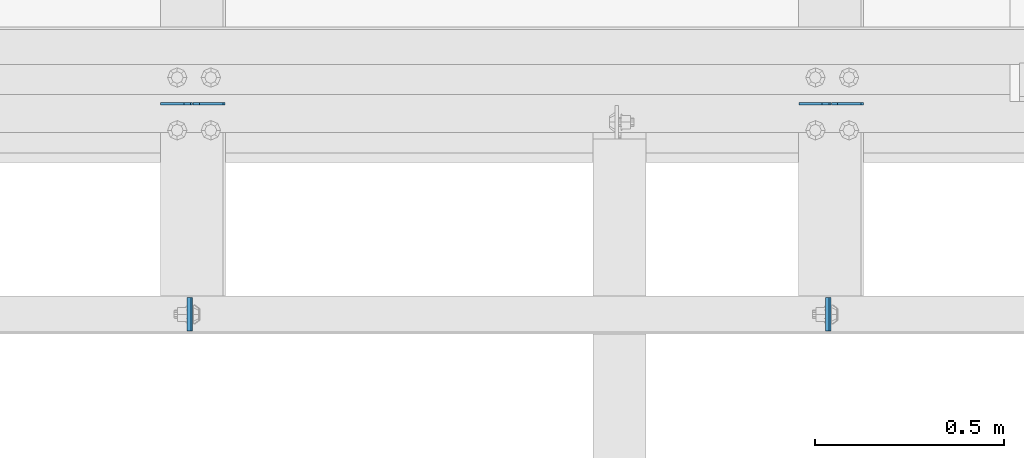
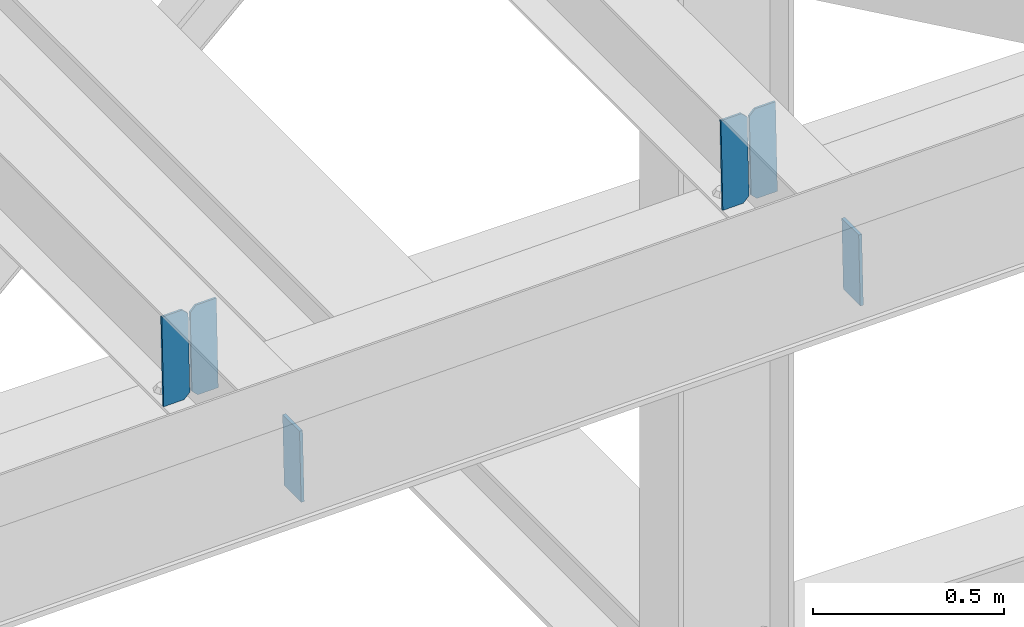
# One storey, part 3193 of 3843: 6 plates, 3 elements without a shape of their own.
"""IFC2X3 building model written with IfcOpenShell, lengths in millimetres."""

from ifc_helpers import new_model, si_unit, frame, origin_with_axes, place, context, subcontext, project, spatial, faceted_brep, material, type_object, element, aggregate, save


model = new_model("IFC2X3")

# Units and contexts
model_context = context("Model", 3, precision=1e-05, world=origin_with_axes())
body_context = subcontext(model_context, "Body", "Model", "MODEL_VIEW")
ifc_project = project(units=[si_unit("LENGTHUNIT", "METRE", prefix="MILLI"), si_unit("AREAUNIT", "SQUARE_METRE"), si_unit("VOLUMEUNIT", "CUBIC_METRE"), si_unit("MASSUNIT", "GRAM", prefix="KILO"), si_unit("TIMEUNIT", "SECOND"), si_unit("PLANEANGLEUNIT", "RADIAN"), si_unit("SOLIDANGLEUNIT", "STERADIAN"), si_unit("THERMODYNAMICTEMPERATUREUNIT", "DEGREE_CELSIUS"), si_unit("LUMINOUSINTENSITYUNIT", "LUMEN")], contexts=[model_context])

# Site, building, storey
site_placement = place(None, origin_with_axes())
site = spatial("IfcSite", under=ifc_project, at=site_placement, CompositionType="ELEMENT")
building_placement = place(site_placement, origin_with_axes())
building = spatial("IfcBuilding", under=site, at=building_placement, Name="Undefined", CompositionType="ELEMENT")
storey_placement = place(building_placement, origin_with_axes())
storey = spatial("IfcBuildingStorey", under=building, at=storey_placement, Name="Undefined", CompositionType="ELEMENT", Elevation=0.0)

# Assembly, plates
assembly_1_placement = place(storey_placement, origin_with_axes())
assembly_1 = element("IfcElementAssembly", 1, at=assembly_1_placement, inside=storey, Name="BEAM", AssemblyPlace="NOTDEFINED", PredefinedType="RIGID_FRAME")
ifc_material = material(Name="STEEL/A572-50")
plate_type_1 = type_object("IfcPlateType", PredefinedType="NOTDEFINED")
plate_1_placement = place(assembly_1_placement, frame((75309.9867956282, 25014.2377038333, 46511.0810232834), z_axis=(4.27769994857954e-05, 0.999999999084655, 9.05023924133274e-07), x_axis=(0.0211520550054438, 0.0, -0.999776270257025)))
plate_1 = element("IfcPlate", 2, at=plate_1_placement, type_object=plate_type_1, material=ifc_material, Name="PLATE", context=body_context, shape_type="Brep", body=[
    faceted_brep([(0.0, -4.76249999999709, 0.0), (0.0, -4.76249999999709, 88.9000015258789), (0.0, 4.76249999999709, 88.9000015258789), (0.0, 4.76249999999709, 0.0), (228.600006102781, -4.7625000004191, 88.9000015257589), (228.600006102781, 4.76249999954598, 88.9000015257443), (228.600006103079, -4.7625000004482, 7.27595761418343e-12), (228.600006103079, 4.76249999954598, -7.27595761418343e-12)], [[[0, 1, 2, 3]], [[1, 4, 5, 2]], [[4, 6, 7, 5]], [[6, 0, 3, 7]], [[5, 7, 3, 2]], [[6, 4, 1, 0]]]),
])
plate_2_placement = place(assembly_1_placement, frame((73620.886795624, 25014.2377038355, 46475.3449829727), z_axis=(4.27769994857954e-05, 0.999999999084655, 9.05023924133274e-07), x_axis=(0.0211520550054438, 0.0, -0.999776270257025)))
plate_2 = element("IfcPlate", 3, at=plate_2_placement, type_object=plate_type_1, material=ifc_material, Name="PLATE", context=body_context, shape_type="Brep", body=[
    faceted_brep([(0.0, -4.76249999999709, 0.0), (0.0, -4.76249999999709, 88.9000015258789), (0.0, 4.76249999999709, 88.9000015258789), (0.0, 4.76249999999709, 0.0), (228.600006102781, -4.7625000004191, 88.9000015257589), (228.600006102781, 4.76249999954598, 88.9000015257443), (228.600006103079, -4.7625000004482, 7.27595761418343e-12), (228.600006103079, 4.76249999954598, -7.27595761418343e-12)], [[[0, 1, 2, 3]], [[1, 4, 5, 2]], [[4, 6, 7, 5]], [[6, 0, 3, 7]], [[5, 7, 3, 2]], [[6, 4, 1, 0]]]),
])
aggregate(assembly_1, [plate_1, plate_2])

assembly_2_placement = place(storey_placement, origin_with_axes())
assembly_2 = element("IfcElementAssembly", 4, at=assembly_2_placement, inside=storey, Name="BEAM", AssemblyPlace="NOTDEFINED", PredefinedType="RIGID_FRAME")
plate_type_2 = type_object("IfcPlateType", PredefinedType="NOTDEFINED")
plate_3_placement = place(assembly_2_placement, frame((75405.9964782674, 25616.7954276443, 46252.244666368), z_axis=(-0.021152098282546, -0.00202236699979404, 0.999774223897558), x_axis=(-0.999776269341419, 4.27870000128944e-05, -0.0211520550071887)))
plate_3 = element("IfcPlate", 5, at=plate_3_placement, type_object=plate_type_2, material=ifc_material, Name="STIFFENER", context=body_context, shape_type="Brep", body=[
    faceted_brep([(0.0, -3.17499999999927, 0.0), (6.83940015733242e-10, -3.17499999996653, 288.924999998613), (6.54836185276508e-10, 3.17500000001746, 288.924999998591), (0.0, 3.17499999999927, 0.0), (61.9125003828667, -3.17499999997744, 288.924999998599), (61.9125003828522, 3.17500000002838, 288.924999998584), (79.3750000013097, -3.17499999997744, 271.462500380039), (79.375000001266, 3.17500000002838, 271.462500380017), (79.375000000713, -3.17499999999927, 17.4624996185448), (79.3750000006694, 3.17500000000291, 17.462499618523), (61.9125003821828, -3.17499999999563, -1.45519152283669e-11), (61.9125003821682, 3.17500000000655, -2.91038304567337e-11)], [[[0, 1, 2, 3]], [[1, 4, 5, 2]], [[4, 6, 7, 5]], [[6, 8, 9, 7]], [[8, 10, 11, 9]], [[10, 0, 3, 11]], [[5, 7, 9, 11, 3, 2]], [[10, 8, 6, 4, 1, 0]]]),
])
plate_4_placement = place(assembly_2_placement, frame((75320.2906575771, 25616.7990955481, 46250.431406477), z_axis=(-0.021152098282546, -0.00202236699979404, 0.999774223897558), x_axis=(-0.999776269341419, 4.27870000128944e-05, -0.0211520550071887)))
plate_4 = element("IfcPlate", 6, at=plate_4_placement, type_object=plate_type_2, material=ifc_material, Name="STIFFENER", context=body_context, shape_type="Brep", body=[
    faceted_brep([(5.82076609134674e-11, -3.17499999999927, 17.4624996185667), (6.25732354819775e-10, -3.17499999997744, 271.462500380054), (5.82076609134674e-10, 3.17500000002474, 271.462500380039), (0.0, 3.17500000000655, 17.4624996185521), (17.462499619156, -3.17499999997744, 288.924999998606), (17.4624996191269, 3.17500000002474, 288.924999998591), (79.3750000013242, -3.17500000025029, 288.924999998591), (79.3750000013097, 3.1749999997337, 288.92499999857), (79.3750000006548, -3.17500000026484, -2.18278728425503e-11), (79.3750000006403, 3.17499999969732, -2.91038304567337e-11), (17.4624996184866, -3.17500000000291, 7.27595761418343e-12), (17.462499618443, 3.17500000000291, -7.27595761418343e-12)], [[[0, 1, 2, 3]], [[1, 4, 5, 2]], [[4, 6, 7, 5]], [[6, 8, 9, 7]], [[8, 10, 11, 9]], [[10, 0, 3, 11]], [[5, 7, 9, 11, 3, 2]], [[10, 8, 6, 4, 1, 0]]]),
])
aggregate(assembly_2, [plate_3, plate_4])

assembly_3_placement = place(storey_placement, origin_with_axes())
assembly_3 = element("IfcElementAssembly", 7, at=assembly_3_placement, inside=storey, Name="BEAM", AssemblyPlace="NOTDEFINED", PredefinedType="RIGID_FRAME")
plate_5_placement = place(assembly_3_placement, frame((73716.8964782636, 25616.7954276443, 46216.5086260688), z_axis=(-0.021152098282546, -0.00202236699979404, 0.999774223897558), x_axis=(-0.999776269341419, 4.27870000128944e-05, -0.0211520550071887)))
plate_5 = element("IfcPlate", 8, at=plate_5_placement, type_object=plate_type_2, material=ifc_material, Name="STIFFENER", context=body_context, shape_type="Brep", body=[
    faceted_brep([(0.0, -3.17499999999927, 0.0), (6.83940015733242e-10, -3.17499999996653, 288.924999998613), (6.54836185276508e-10, 3.17500000001746, 288.924999998591), (0.0, 3.17499999999927, 0.0), (61.9125003828667, -3.17499999997744, 288.924999998599), (61.9125003828522, 3.17500000002838, 288.924999998584), (79.3750000013097, -3.17499999997744, 271.462500380039), (79.375000001266, 3.17500000002838, 271.462500380017), (79.375000000713, -3.17499999999927, 17.4624996185448), (79.3750000006694, 3.17500000000291, 17.462499618523), (61.9125003821828, -3.17499999999563, -1.45519152283669e-11), (61.9125003821682, 3.17500000000655, -2.91038304567337e-11)], [[[0, 1, 2, 3]], [[1, 4, 5, 2]], [[4, 6, 7, 5]], [[6, 8, 9, 7]], [[8, 10, 11, 9]], [[10, 0, 3, 11]], [[5, 7, 9, 11, 3, 2]], [[10, 8, 6, 4, 1, 0]]]),
])
plate_6_placement = place(assembly_3_placement, frame((73631.1906575733, 25616.7990955481, 46214.6953661778), z_axis=(-0.021152098282546, -0.00202236699979404, 0.999774223897558), x_axis=(-0.999776269341419, 4.27870000128944e-05, -0.0211520550071887)))
plate_6 = element("IfcPlate", 9, at=plate_6_placement, type_object=plate_type_2, material=ifc_material, Name="STIFFENER", context=body_context, shape_type="Brep", body=[
    faceted_brep([(5.82076609134674e-11, -3.17499999999927, 17.4624996185667), (6.25732354819775e-10, -3.17499999997744, 271.462500380054), (5.82076609134674e-10, 3.17500000002474, 271.462500380039), (0.0, 3.17500000000655, 17.4624996185521), (17.462499619156, -3.17499999997744, 288.924999998606), (17.4624996191269, 3.17500000002474, 288.924999998591), (79.3750000013242, -3.17500000025029, 288.924999998591), (79.3750000013097, 3.1749999997337, 288.92499999857), (79.3750000006548, -3.17500000026484, -2.18278728425503e-11), (79.3750000006403, 3.17499999969732, -2.91038304567337e-11), (17.4624996184866, -3.17500000000291, 7.27595761418343e-12), (17.462499618443, 3.17500000000291, -7.27595761418343e-12)], [[[0, 1, 2, 3]], [[1, 4, 5, 2]], [[4, 6, 7, 5]], [[6, 8, 9, 7]], [[8, 10, 11, 9]], [[10, 0, 3, 11]], [[5, 7, 9, 11, 3, 2]], [[10, 8, 6, 4, 1, 0]]]),
])
aggregate(assembly_3, [plate_5, plate_6])

save(model, "model.ifc")
